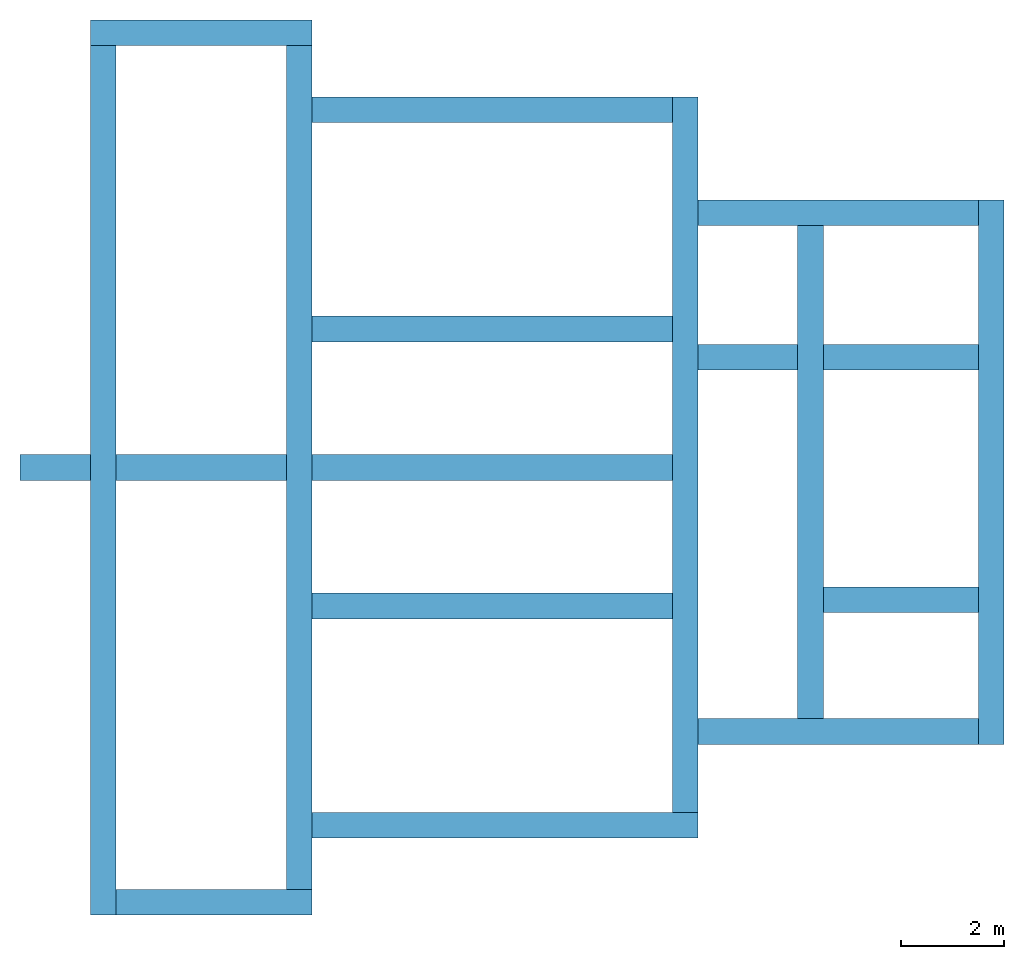
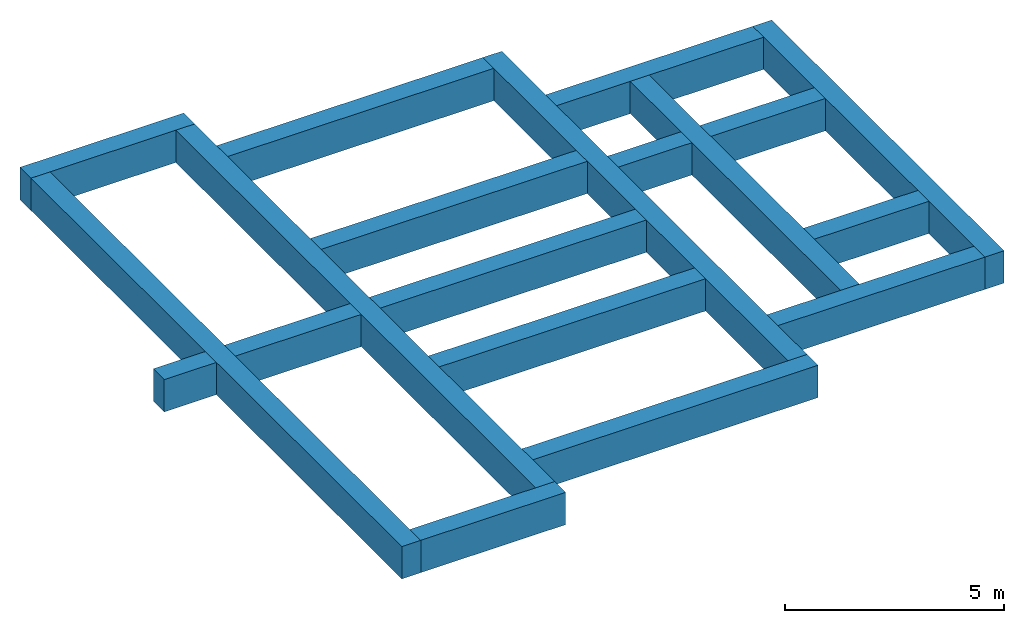
# One storey: 16 walls, 3 openings.
"""IFC2X3 building model written with IfcOpenShell, lengths in millimetres."""

from ifc_helpers import new_model, entity, si_unit, converted_unit, derived_unit, direction, frame, frame_2d, origin, place, context, subcontext, project, spatial, rectangle, extrude, material, layer, layer_set, layer_usage, type_object, element, save


model = new_model("IFC2X3")

# Units and contexts
model_context = context("Model", 3, precision=0.01, world=origin(), true_north=direction((6.12303176911189e-17, 1.0)))
body_context = subcontext(model_context, "Body", "Model", "MODEL_VIEW")
ifc_project = project(units=[si_unit("LENGTHUNIT", "METRE", prefix="MILLI"), si_unit("AREAUNIT", "SQUARE_METRE"), si_unit("VOLUMEUNIT", "CUBIC_METRE"), converted_unit("PLANEANGLEUNIT", "DEGREE", entity("IfcRatioMeasure", 0.0174532925199433), si_unit("PLANEANGLEUNIT", "RADIAN"), dimensions=[0, 0, 0, 0, 0, 0, 0]), si_unit("MASSUNIT", "GRAM", prefix="KILO"), derived_unit("MASSDENSITYUNIT", [(si_unit("MASSUNIT", "GRAM", prefix="KILO"), 1), (si_unit("LENGTHUNIT", "METRE"), -3)]), si_unit("TIMEUNIT", "SECOND"), si_unit("FREQUENCYUNIT", "HERTZ"), si_unit("THERMODYNAMICTEMPERATUREUNIT", "DEGREE_CELSIUS"), derived_unit("THERMALTRANSMITTANCEUNIT", [(si_unit("MASSUNIT", "GRAM", prefix="KILO"), 1), (si_unit("THERMODYNAMICTEMPERATUREUNIT", "KELVIN"), -1), (si_unit("TIMEUNIT", "SECOND"), -3)]), derived_unit("VOLUMETRICFLOWRATEUNIT", [(si_unit("LENGTHUNIT", "METRE"), 3), (si_unit("TIMEUNIT", "SECOND"), -1)]), si_unit("ELECTRICCURRENTUNIT", "AMPERE"), si_unit("ELECTRICVOLTAGEUNIT", "VOLT"), si_unit("POWERUNIT", "WATT"), si_unit("FORCEUNIT", "NEWTON", prefix="KILO"), si_unit("ILLUMINANCEUNIT", "LUX"), si_unit("LUMINOUSFLUXUNIT", "LUMEN"), si_unit("LUMINOUSINTENSITYUNIT", "CANDELA"), derived_unit("USERDEFINED", [(si_unit("MASSUNIT", "GRAM", prefix="KILO"), -1), (si_unit("LENGTHUNIT", "METRE"), -2), (si_unit("TIMEUNIT", "SECOND"), 3), (si_unit("LUMINOUSFLUXUNIT", "LUMEN"), 1)]), derived_unit("LINEARVELOCITYUNIT", [(si_unit("LENGTHUNIT", "METRE"), 1), (si_unit("TIMEUNIT", "SECOND"), -1)]), si_unit("PRESSUREUNIT", "PASCAL"), derived_unit("USERDEFINED", [(si_unit("LENGTHUNIT", "METRE"), -2), (si_unit("MASSUNIT", "GRAM", prefix="KILO"), 1), (si_unit("TIMEUNIT", "SECOND"), -2)])], contexts=[model_context])

# Site, building, storey
site_placement = place(None, origin())
site = spatial("IfcSite", under=ifc_project, at=site_placement, CompositionType="ELEMENT")
building_placement = place(site_placement, origin())
building = spatial("IfcBuilding", under=site, at=building_placement, CompositionType="ELEMENT")
storey_placement = place(building_placement, frame((0.0, 0.0, -1800.0)))
storey = spatial("IfcBuildingStorey", under=building, at=storey_placement, Name="A2 Bottom of Foundation", CompositionType="ELEMENT", Elevation=-1800.0)

# Walls
ifc_material = material(Name="02_C40/50")
ifc_layer = layer(ifc_material, 500.0)
ifc_layer_set = layer_set([ifc_layer], Name="Basic Wall:500mm Beton")
ifc_layer_usage_1 = layer_usage(ifc_layer_set, "AXIS2", "NEGATIVE", 250.0)
wall_type = type_object("IfcWallType", Name="Basic Wall:500mm Beton", PredefinedType="STANDARD", material=ifc_layer_set)
wall_1_placement = place(storey_placement, frame((21393.4900708518, -60361.2395851399, 0.0), z_axis=(0.0, 0.0, 1.0), x_axis=(-1.0, 0.0, 0.0)))
element("IfcWallStandardCase", 1, at=wall_1_placement, inside=storey, type_object=wall_type, material=ifc_layer_usage_1, Name="Basic Wall:500mm Beton", ObjectType="Basic Wall:500mm Beton", context=body_context, shape_type="SweptSolid", body=[
    extrude(rectangle(XDim=4320.00000000004, YDim=500.000000000008, at=frame_2d((2160.00000000002, 4.83169060316868e-13), x_axis=(-1.0, 0.0))), origin(), (0.0, 0.0, 1.0), 900.0),
])
ifc_layer_usage_2 = layer_usage(ifc_layer_set, "AXIS2", "NEGATIVE", 250.0)
wall_2_placement = place(storey_placement, frame((17323.4900708518, -60611.2395851399, 0.0), z_axis=(0.0, 0.0, 1.0), x_axis=(0.0, -1.0, 0.0)))
element("IfcWallStandardCase", 2, at=wall_2_placement, inside=storey, type_object=wall_type, material=ifc_layer_usage_2, Name="Basic Wall:500mm Beton", ObjectType="Basic Wall:500mm Beton", context=body_context, shape_type="SweptSolid", body=[
    extrude(rectangle(XDim=16940.0, YDim=499.999999999999, at=frame_2d((8469.99999999999, -5.6843418860808e-14), x_axis=(-1.0, 0.0))), origin(), (0.0, 0.0, 1.0), 900.0),
])
ifc_layer_usage_3 = layer_usage(ifc_layer_set, "AXIS2", "NEGATIVE", 250.0)
wall_3_placement = place(storey_placement, frame((17573.4900708518, -77301.2395851399, 0.0)))
element("IfcWallStandardCase", 3, at=wall_3_placement, inside=storey, type_object=wall_type, material=ifc_layer_usage_3, Name="Basic Wall:500mm Beton", ObjectType="Basic Wall:500mm Beton", context=body_context, shape_type="SweptSolid", body=[
    extrude(rectangle(XDim=3820.00000000002, YDim=500.000000000008, at=frame_2d((1910.00000000001, -7.105427357601e-14), x_axis=(-1.0, 0.0))), origin(), (0.0, 0.0, 1.0), 900.0),
])
ifc_layer_usage_4 = layer_usage(ifc_layer_set, "AXIS2", "NEGATIVE", 250.0)
wall_4_placement = place(storey_placement, frame((21143.4900708518, -77051.2395851399, 0.0), z_axis=(0.0, 0.0, 1.0), x_axis=(0.0, 1.0, 0.0)))
element("IfcWallStandardCase", 4, at=wall_4_placement, inside=storey, type_object=wall_type, material=ifc_layer_usage_4, Name="Basic Wall:500mm Beton", ObjectType="Basic Wall:500mm Beton", context=body_context, shape_type="SweptSolid", body=[
    extrude(rectangle(XDim=16440.0, YDim=499.999999999999, at=frame_2d((8219.99999999999, -1.00897068477934e-12), x_axis=(-1.0, 0.0))), origin(), (0.0, 0.0, 1.0), 900.0),
])
ifc_layer_usage_5 = layer_usage(ifc_layer_set, "AXIS2", "NEGATIVE", 250.0)
wall_5_placement = place(storey_placement, frame((21393.4900708518, -75801.2395851399, 0.0)))
element("IfcWallStandardCase", 5, at=wall_5_placement, inside=storey, type_object=wall_type, material=ifc_layer_usage_5, Name="Basic Wall:500mm Beton", ObjectType="Basic Wall:500mm Beton", context=body_context, shape_type="SweptSolid", body=[
    extrude(rectangle(XDim=7519.99999999999, YDim=500.000000000008, at=frame_2d((3759.99999999999, -1.13686837721616e-13), x_axis=(-1.0, 0.0))), origin(), (0.0, 0.0, 1.0), 900.0),
])
ifc_layer_usage_6 = layer_usage(ifc_layer_set, "AXIS2", "NEGATIVE", 250.0)
wall_6_placement = place(storey_placement, frame((28663.4900708518, -75551.2395851399, 0.0), z_axis=(0.0, 0.0, 1.0), x_axis=(0.0, 1.0, 0.0)))
element("IfcWallStandardCase", 6, at=wall_6_placement, inside=storey, type_object=wall_type, material=ifc_layer_usage_6, Name="Basic Wall:500mm Beton", ObjectType="Basic Wall:500mm Beton", context=body_context, shape_type="SweptSolid", body=[
    extrude(rectangle(XDim=13940.0, YDim=499.999999999999, at=frame_2d((6969.99999999999, 0.0), x_axis=(-1.0, 0.0))), origin(), (0.0, 0.0, 1.0), 900.0),
])

# Wall, openings
ifc_layer_usage_7 = layer_usage(ifc_layer_set, "AXIS2", "NEGATIVE", 250.0)
wall_7_placement = place(storey_placement, frame((28413.4900708518, -68831.2395851399, 0.0), z_axis=(0.0, 0.0, 1.0), x_axis=(-1.0, 0.0, 0.0)))
wall_7 = element("IfcWallStandardCase", 7, at=wall_7_placement, inside=storey, type_object=wall_type, material=ifc_layer_usage_7, Name="Basic Wall:500mm Beton", ObjectType="Basic Wall:500mm Beton", context=body_context, shape_type="SweptSolid", body=[
    extrude(rectangle(XDim=12715.0, YDim=500.000000000008, at=frame_2d((6357.5, -4.9737991503207e-13), x_axis=(-1.0, 0.0))), origin(), (0.0, 0.0, 1.0), 900.0),
])
opening_1_placement = place(storey_placement, frame((28413.4900708518, -68831.2395851399, 0.0), z_axis=(0.0, 0.0, 1.0), x_axis=(-1.0, 0.0, 0.0)))
element("IfcOpeningElement", 8, at=opening_1_placement, cuts=wall_7, Name="Basic Wall:500mm Beton:1", ObjectType="Opening", context=body_context, shape_type="SweptSolid", body=[
    extrude(rectangle(XDim=900.0, YDim=499.999999999999, at=frame_2d((0.0, -4.33431068813661e-12), x_axis=(1.0, 0.0))), frame((7520.0, 0.0, 450.0), z_axis=(-1.0, 0.0, 0.0), x_axis=(0.0, 0.0, 1.0)), (0.0, 0.0, 1.0), 499.999999999999),
])
opening_2_placement = place(storey_placement, frame((28413.4900708518, -68831.2395851399, 0.0), z_axis=(0.0, 0.0, 1.0), x_axis=(-1.0, 0.0, 0.0)))
element("IfcOpeningElement", 9, at=opening_2_placement, cuts=wall_7, Name="Basic Wall:500mm Beton:2", ObjectType="Opening", context=body_context, shape_type="SweptSolid", body=[
    extrude(rectangle(XDim=900.0, YDim=499.999999999999, at=frame_2d((0.0, -4.33431068813661e-12), x_axis=(1.0, 0.0))), frame((11340.0, 0.0, 450.0), z_axis=(-1.0, 0.0, 0.0), x_axis=(0.0, 0.0, 1.0)), (0.0, 0.0, 1.0), 500.000000000001),
])

# Walls
ifc_layer_usage_8 = layer_usage(ifc_layer_set, "AXIS2", "POSITIVE", -250.0)
wall_8_placement = place(storey_placement, frame((21393.4900708518, -61861.2395851399, 0.0)))
element("IfcWallStandardCase", 10, at=wall_8_placement, inside=storey, type_object=wall_type, material=ifc_layer_usage_8, Name="Basic Wall:500mm Beton", ObjectType="Basic Wall:500mm Beton", context=body_context, shape_type="SweptSolid", body=[
    extrude(rectangle(XDim=7019.99999999997, YDim=500.000000000008, at=frame_2d((3509.99999999999, -1.74793512996985e-12), x_axis=(-1.0, 0.0))), origin(), (0.0, 0.0, 1.0), 900.0),
])
ifc_layer_usage_9 = layer_usage(ifc_layer_set, "AXIS2", "NEGATIVE", 250.0)
wall_9_placement = place(storey_placement, frame((31103.4900708518, -73725.8241905963, 0.0), z_axis=(0.0, 0.0, 1.0), x_axis=(0.0, 1.0, 0.0)))
element("IfcWallStandardCase", 11, at=wall_9_placement, inside=storey, type_object=wall_type, material=ifc_layer_usage_9, Name="Basic Wall:500mm Beton", ObjectType="Basic Wall:500mm Beton", context=body_context, shape_type="SweptSolid", body=[
    extrude(rectangle(XDim=9610.00000000001, YDim=499.999999999999, at=frame_2d((4805.0, 9.52127265918534e-13), x_axis=(-1.0, 0.0))), origin(), (0.0, 0.0, 1.0), 900.0),
])
ifc_layer_usage_10 = layer_usage(ifc_layer_set, "AXIS2", "NEGATIVE", 250.0)
wall_10_placement = place(storey_placement, frame((34623.4900708518, -74225.8241905963, 0.0), z_axis=(0.0, 0.0, 1.0), x_axis=(0.0, 1.0, 0.0)))
element("IfcWallStandardCase", 12, at=wall_10_placement, inside=storey, type_object=wall_type, material=ifc_layer_usage_10, Name="Basic Wall:500mm Beton", ObjectType="Basic Wall:500mm Beton", context=body_context, shape_type="SweptSolid", body=[
    extrude(rectangle(XDim=10610.0, YDim=499.999999999999, at=frame_2d((5305.0, 1.73372427525464e-12), x_axis=(-1.0, 0.0))), origin(), (0.0, 0.0, 1.0), 900.0),
])
ifc_layer_usage_11 = layer_usage(ifc_layer_set, "AXIS2", "POSITIVE", -250.0)
wall_11_placement = place(storey_placement, frame((28913.4900708518, -63865.8241905963, 0.0)))
element("IfcWallStandardCase", 13, at=wall_11_placement, inside=storey, type_object=wall_type, material=ifc_layer_usage_11, Name="Basic Wall:500mm Beton", ObjectType="Basic Wall:500mm Beton", context=body_context, shape_type="SweptSolid", body=[
    extrude(rectangle(XDim=5459.99999999999, YDim=500.000000000008, at=frame_2d((2730.0, 8.5265128291212e-14), x_axis=(-1.0, 0.0))), origin(), (0.0, 0.0, 1.0), 900.0),
])

# Wall, opening
ifc_layer_usage_12 = layer_usage(ifc_layer_set, "AXIS2", "POSITIVE", -250.0)
wall_12_placement = place(storey_placement, frame((28913.4900708518, -66685.8241905963, 0.0)))
wall_12 = element("IfcWallStandardCase", 14, at=wall_12_placement, inside=storey, type_object=wall_type, material=ifc_layer_usage_12, Name="Basic Wall:500mm Beton", ObjectType="Basic Wall:500mm Beton", context=body_context, shape_type="SweptSolid", body=[
    extrude(rectangle(XDim=5459.99999999999, YDim=500.000000000008, at=frame_2d((2730.0, 8.5265128291212e-14), x_axis=(-1.0, 0.0))), origin(), (0.0, 0.0, 1.0), 900.0),
])
opening_3_placement = place(storey_placement, frame((28913.4900708518, -66685.8241905963, 0.0)))
element("IfcOpeningElement", 15, at=opening_3_placement, cuts=wall_12, Name="Basic Wall:500mm Beton:1", ObjectType="Opening", context=body_context, shape_type="SweptSolid", body=[
    extrude(rectangle(XDim=900.0, YDim=499.999999999999, at=frame_2d((0.0, 4.33431068813661e-12), x_axis=(1.0, 0.0))), frame((1940.0, 0.0, 450.0), z_axis=(1.0, 0.0, 0.0), x_axis=(0.0, 0.0, -1.0)), (0.0, 0.0, 1.0), 499.999999999999),
])

# Walls
ifc_layer_usage_13 = layer_usage(ifc_layer_set, "AXIS2", "NEGATIVE", 250.0)
wall_13_placement = place(storey_placement, frame((28913.4900708518, -73975.8241905963, 0.0)))
element("IfcWallStandardCase", 16, at=wall_13_placement, inside=storey, type_object=wall_type, material=ifc_layer_usage_13, Name="Basic Wall:500mm Beton", ObjectType="Basic Wall:500mm Beton", context=body_context, shape_type="SweptSolid", body=[
    extrude(rectangle(XDim=5460.0, YDim=500.000000000008, at=frame_2d((2730.0, -3.46744855050929e-12), x_axis=(-1.0, 0.0))), origin(), (0.0, 0.0, 1.0), 900.0),
])
ifc_layer_usage_14 = layer_usage(ifc_layer_set, "AXIS2", "POSITIVE", -250.0)
wall_14_placement = place(storey_placement, frame((31353.4900708518, -71410.8241905963, 0.0)))
element("IfcWallStandardCase", 17, at=wall_14_placement, inside=storey, type_object=wall_type, material=ifc_layer_usage_14, Name="Basic Wall:500mm Beton", ObjectType="Basic Wall:500mm Beton", context=body_context, shape_type="SweptSolid", body=[
    extrude(rectangle(XDim=3019.99999999999, YDim=500.000000000008, at=frame_2d((1510.0, 5.11590769747272e-13), x_axis=(-1.0, 0.0))), origin(), (0.0, 0.0, 1.0), 900.0),
])
ifc_layer_usage_15 = layer_usage(ifc_layer_set, "AXIS2", "NEGATIVE", 250.0)
wall_15_placement = place(storey_placement, frame((28413.4900708518, -71531.2395851399, 0.0), z_axis=(0.0, 0.0, 1.0), x_axis=(-1.0, 0.0, 0.0)))
element("IfcWallStandardCase", 18, at=wall_15_placement, inside=storey, type_object=wall_type, material=ifc_layer_usage_15, Name="Basic Wall:500mm Beton", ObjectType="Basic Wall:500mm Beton", context=body_context, shape_type="SweptSolid", body=[
    extrude(rectangle(XDim=7019.99999999999, YDim=500.000000000008, at=frame_2d((3509.99999999999, -1.30739863379858e-12), x_axis=(-1.0, 0.0))), origin(), (0.0, 0.0, 1.0), 900.0),
])
ifc_layer_usage_16 = layer_usage(ifc_layer_set, "AXIS2", "POSITIVE", -250.0)
wall_16_placement = place(storey_placement, frame((28413.4900708518, -66131.2395851399, 0.0), z_axis=(0.0, 0.0, 1.0), x_axis=(-1.0, 0.0, 0.0)))
element("IfcWallStandardCase", 19, at=wall_16_placement, inside=storey, type_object=wall_type, material=ifc_layer_usage_16, Name="Basic Wall:500mm Beton", ObjectType="Basic Wall:500mm Beton", context=body_context, shape_type="SweptSolid", body=[
    extrude(rectangle(XDim=7019.99999999998, YDim=500.000000000008, at=frame_2d((3509.99999999999, -1.17950094136177e-12), x_axis=(-1.0, 0.0))), origin(), (0.0, 0.0, 1.0), 900.0),
])

save(model, "model.ifc")
